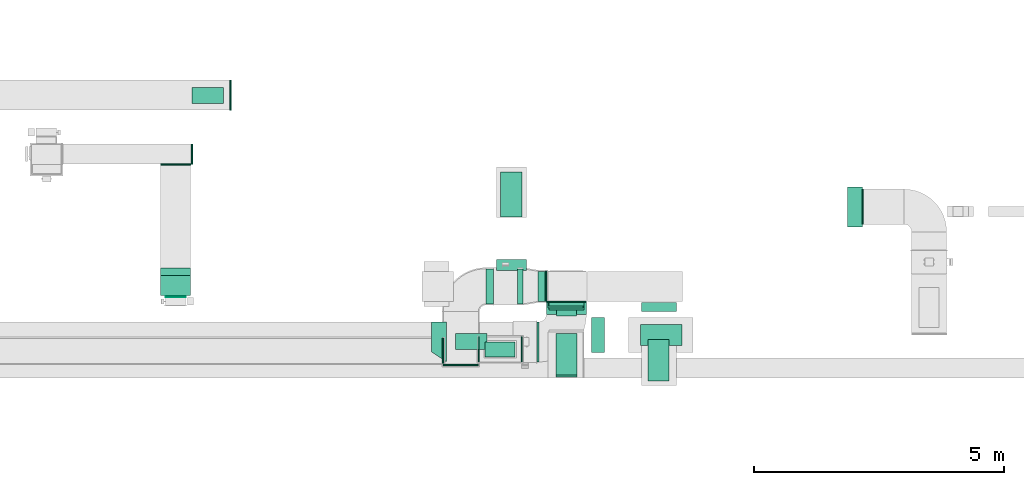
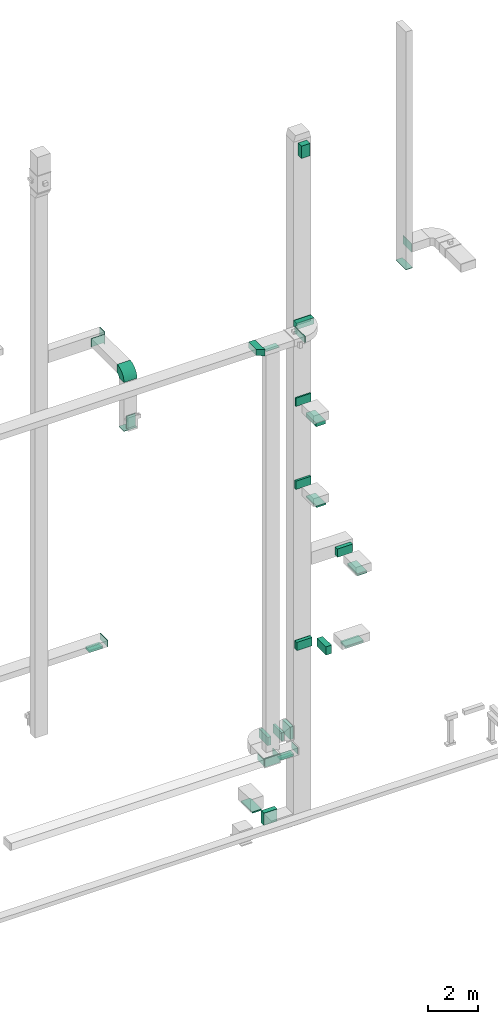
# One storey, part 15 of 25: 22 flow fittings, 20 flow segments, 3 flow terminals.
"""IFC2X3 building model written with IfcOpenShell, lengths in millimetres."""

from ifc_helpers import new_model, entity, si_unit, converted_unit, derived_unit, direction, frame, frame_2d, origin, origin_2d_with_axis, place, context, subcontext, project, spatial, polyline, circle_curve, parameter, trimmed, segment, composite_curve, rectangle, outline, extrude, source, transform, mapped, material, type_object, type_shapes, element, save


model = new_model("IFC2X3")

# Units and contexts
model_context = context("Model", 3, precision=0.01, world=origin(), true_north=direction((6.12303176911189e-17, 1.0)))
body_context = subcontext(model_context, "Body", "Model", "MODEL_VIEW")
ifc_project = project(units=[si_unit("LENGTHUNIT", "METRE", prefix="MILLI"), si_unit("AREAUNIT", "SQUARE_METRE"), si_unit("VOLUMEUNIT", "CUBIC_METRE"), converted_unit("PLANEANGLEUNIT", "DEGREE", entity("IfcRatioMeasure", 0.0174532925199433), si_unit("PLANEANGLEUNIT", "RADIAN"), dimensions=[0, 0, 0, 0, 0, 0, 0]), si_unit("MASSUNIT", "GRAM", prefix="KILO"), derived_unit("MASSDENSITYUNIT", [(si_unit("MASSUNIT", "GRAM", prefix="KILO"), 1), (si_unit("LENGTHUNIT", "METRE"), -3)]), derived_unit("MOMENTOFINERTIAUNIT", [(si_unit("LENGTHUNIT", "METRE"), 4)]), si_unit("TIMEUNIT", "SECOND"), si_unit("FREQUENCYUNIT", "HERTZ"), si_unit("THERMODYNAMICTEMPERATUREUNIT", "DEGREE_CELSIUS"), derived_unit("THERMALTRANSMITTANCEUNIT", [(si_unit("MASSUNIT", "GRAM", prefix="KILO"), 1), (si_unit("THERMODYNAMICTEMPERATUREUNIT", "KELVIN"), -1), (si_unit("TIMEUNIT", "SECOND"), -3)]), derived_unit("VOLUMETRICFLOWRATEUNIT", [(si_unit("LENGTHUNIT", "METRE"), 3), (si_unit("TIMEUNIT", "SECOND"), -1)]), derived_unit("MASSFLOWRATEUNIT", [(si_unit("MASSUNIT", "GRAM", prefix="KILO"), 1), (si_unit("TIMEUNIT", "SECOND"), -1)]), derived_unit("ROTATIONALFREQUENCYUNIT", [(si_unit("TIMEUNIT", "SECOND"), -1)]), si_unit("ELECTRICCURRENTUNIT", "AMPERE"), si_unit("ELECTRICVOLTAGEUNIT", "VOLT"), si_unit("POWERUNIT", "WATT"), si_unit("FORCEUNIT", "NEWTON", prefix="KILO"), si_unit("ILLUMINANCEUNIT", "LUX"), si_unit("LUMINOUSFLUXUNIT", "LUMEN"), si_unit("LUMINOUSINTENSITYUNIT", "CANDELA"), derived_unit("USERDEFINED", [(si_unit("MASSUNIT", "GRAM", prefix="KILO"), -1), (si_unit("LENGTHUNIT", "METRE"), -2), (si_unit("TIMEUNIT", "SECOND"), 3), (si_unit("LUMINOUSFLUXUNIT", "LUMEN"), 1)]), derived_unit("LINEARVELOCITYUNIT", [(si_unit("LENGTHUNIT", "METRE"), 1), (si_unit("TIMEUNIT", "SECOND"), -1)]), si_unit("PRESSUREUNIT", "PASCAL"), derived_unit("USERDEFINED", [(si_unit("LENGTHUNIT", "METRE"), -2), (si_unit("MASSUNIT", "GRAM", prefix="KILO"), 1), (si_unit("TIMEUNIT", "SECOND"), -2)]), derived_unit("LINEARFORCEUNIT", [(si_unit("MASSUNIT", "GRAM", prefix="KILO"), 1), (si_unit("LENGTHUNIT", "METRE"), 1), (si_unit("TIMEUNIT", "SECOND"), -2), (si_unit("LENGTHUNIT", "METRE"), -1)]), derived_unit("PLANARFORCEUNIT", [(si_unit("MASSUNIT", "GRAM", prefix="KILO"), 1), (si_unit("LENGTHUNIT", "METRE"), 1), (si_unit("TIMEUNIT", "SECOND"), -2), (si_unit("LENGTHUNIT", "METRE"), -2)])], contexts=[model_context])

# Site, building, storey
site_placement = place(None, origin())
site = spatial("IfcSite", under=ifc_project, at=site_placement, CompositionType="ELEMENT")
building_placement = place(site_placement, origin())
building = spatial("IfcBuilding", under=site, at=building_placement, CompositionType="ELEMENT")
storey_placement = place(building_placement, origin())
storey = spatial("IfcBuildingStorey", under=building, at=storey_placement, CompositionType="ELEMENT", Elevation=0.0)

# Flow segments
duct_segment_type_1 = type_object("IfcDuctSegmentType", PredefinedType="NOTDEFINED")
flow_segment_1_placement = place(storey_placement, frame((62668.85, 10217.03, 30600.0)))
element("IfcFlowSegment", 1, at=flow_segment_1_placement, inside=storey, type_object=duct_segment_type_1, context=body_context, shape_type="SweptSolid", body=[
    extrude(rectangle(XDim=271.467042236398, YDim=400.000000000004, at=origin_2d_with_axis()), frame((200.0, 135.73, 0.0), z_axis=(0.0, 0.0, 1.0), x_axis=(0.0, 1.0, 0.0)), (0.0, 0.0, 1.0), 600.000000000002),
])
flow_segment_2_placement = place(storey_placement, frame((62659.63, 9000.34, 14399.25)))
element("IfcFlowSegment", 2, at=flow_segment_2_placement, inside=storey, type_object=duct_segment_type_1, context=body_context, shape_type="SweptSolid", body=[
    extrude(rectangle(XDim=425.000000000007, YDim=825.0, at=origin_2d_with_axis()), frame((212.5, 412.5, 0.0)), (0.0, 0.0, 1.0), 80.7499999999946),
])
flow_segment_3_placement = place(storey_placement, frame((64497.81, 8920.34, 10500.0)))
element("IfcFlowSegment", 3, at=flow_segment_3_placement, inside=storey, type_object=duct_segment_type_1, context=body_context, shape_type="SweptSolid", body=[
    extrude(rectangle(XDim=825.000000000001, YDim=424.999999999999, at=origin_2d_with_axis()), frame((212.5, 412.5, 0.0), z_axis=(0.0, 0.0, 1.0), x_axis=(0.0, 1.0, 0.0)), (0.0, 0.0, 1.0), 79.9999999999818),
])
flow_segment_4_placement = place(storey_placement, frame((62661.63, 9040.34, 18299.51)))
element("IfcFlowSegment", 4, at=flow_segment_4_placement, inside=storey, type_object=duct_segment_type_1, context=body_context, shape_type="SweptSolid", body=[
    extrude(rectangle(XDim=425.000000000007, YDim=825.0, at=origin_2d_with_axis()), frame((212.5, 412.5, 0.0), z_axis=(0.0, 0.0, 1.0), x_axis=(-1.0, 0.0, 0.0)), (0.0, 0.0, 1.0), 180.490931807302),
])
flow_segment_5_placement = place(storey_placement, frame((64355.36, 9625.06, 6600.0)))
element("IfcFlowSegment", 5, at=flow_segment_5_placement, inside=storey, type_object=duct_segment_type_1, context=body_context, shape_type="SweptSolid", body=[
    extrude(rectangle(XDim=425.0, YDim=825.000000000003, at=origin_2d_with_axis()), frame((412.5, 212.5, 0.0), z_axis=(0.0, 0.0, 1.0), x_axis=(0.0, -1.0, 0.0)), (0.0, 0.0, 1.0), 79.9999999999991),
])
flow_segment_6_placement = place(storey_placement, frame((62307.09, 10508.51, 2350.0)))
element("IfcFlowSegment", 6, at=flow_segment_6_placement, inside=storey, type_object=duct_segment_type_1, context=body_context, shape_type="SweptSolid", body=[
    extrude(rectangle(XDim=143.50000000008, YDim=600.0, at=origin_2d_with_axis()), frame((71.75, 300.0, 0.0), z_axis=(0.0, 0.0, 1.0), x_axis=(-1.0, 0.0, 0.0)), (0.0, 0.0, 1.0), 600.0),
])
flow_segment_7_placement = place(storey_placement, frame((61244.35, 9400.08, 2400.0)))
element("IfcFlowSegment", 7, at=flow_segment_7_placement, inside=storey, type_object=duct_segment_type_1, context=body_context, shape_type="SweptSolid", body=[
    extrude(rectangle(XDim=600.000000000002, YDim=300.0, at=origin_2d_with_axis()), frame((300.0, 150.0, 0.0)), (0.0, 0.0, 1.0), 79.999999999987),
])
flow_segment_8_placement = place(storey_placement, frame((61557.63, 12193.5, -1980.0)))
element("IfcFlowSegment", 8, at=flow_segment_8_placement, inside=storey, type_object=duct_segment_type_1, context=body_context, shape_type="SweptSolid", body=[
    extrude(rectangle(XDim=900.0, YDim=425.000000000004, at=origin_2d_with_axis()), frame((212.5, 450.0, 0.0), z_axis=(0.0, 0.0, 1.0), x_axis=(4.54891432006358e-06, 1.0, 0.0)), (0.0, 0.0, 1.0), 60.4869889686039),
])
flow_segment_9_placement = place(storey_placement, frame((61470.14, 11128.5, -1899.51)))
element("IfcFlowSegment", 9, at=flow_segment_9_placement, inside=storey, type_object=duct_segment_type_1, context=body_context, shape_type="SweptSolid", body=[
    extrude(rectangle(XDim=221.220937838014, YDim=600.000000000002, at=origin_2d_with_axis()), frame((300.0, 110.61, 0.0), z_axis=(0.0, 0.0, 1.0), x_axis=(0.0, 1.0, 0.0)), (0.0, 0.0, 1.0), 600.0),
])
flow_segment_10_placement = place(storey_placement, frame((55390.61, 14462.37, 6600.0)))
element("IfcFlowSegment", 10, at=flow_segment_10_placement, inside=storey, type_object=duct_segment_type_1, context=body_context, shape_type="SweptSolid", body=[
    extrude(rectangle(XDim=324.999999999998, YDim=624.999999999996, at=origin_2d_with_axis()), frame((312.5, 162.5, 0.0), z_axis=(0.0, 0.0, 1.0), x_axis=(0.0, -1.0, 0.0)), (0.0, 0.0, 1.0), 80.0000000000002),
])
flow_segment_11_placement = place(storey_placement, frame((62507.0, 10379.54, 14500.0)))
element("IfcFlowSegment", 11, at=flow_segment_11_placement, inside=storey, type_object=duct_segment_type_1, context=body_context, shape_type="SweptSolid", body=[
    extrude(rectangle(XDim=104.948641174258, YDim=700.0, at=origin_2d_with_axis()), frame((350.01, 52.52, 0.0), z_axis=(0.0, 0.0, 1.0), x_axis=(-0.000129957297672545, 0.99999999155555, 0.0)), (0.0, 0.0, 1.0), 400.0),
])
flow_segment_12_placement = place(storey_placement, frame((62518.99, 10412.6, 18500.0)))
element("IfcFlowSegment", 12, at=flow_segment_12_placement, inside=storey, type_object=duct_segment_type_1, context=body_context, shape_type="SweptSolid", body=[
    extrude(rectangle(XDim=71.0457855893592, YDim=700.000000000003, at=origin_2d_with_axis()), frame((350.01, 35.58, 0.0), z_axis=(0.0, 0.0, 1.0), x_axis=(-0.000157457136900827, 0.999999987603625, 0.0)), (0.0, 0.0, 1.0), 400.0),
])
flow_segment_13_placement = place(storey_placement, frame((62469.72, 10248.83, 22350.0)))
element("IfcFlowSegment", 13, at=flow_segment_13_placement, inside=storey, type_object=duct_segment_type_1, context=body_context, shape_type="SweptSolid", body=[
    extrude(rectangle(XDim=239.665570609249, YDim=800.000000000004, at=origin_2d_with_axis()), frame((400.0, 119.83, 0.0), z_axis=(0.0, 0.0, 1.0), x_axis=(-3.44018263539569e-06, -1.0, 0.0)), (0.0, 0.0, 1.0), 300.000000000001),
])
flow_segment_14_placement = place(storey_placement, frame((62279.43, 9298.83, 22350.0)))
element("IfcFlowSegment", 14, at=flow_segment_14_placement, inside=storey, type_object=duct_segment_type_1, context=body_context, shape_type="SweptSolid", body=[
    extrude(rectangle(XDim=40.2898557493053, YDim=800.000000000001, at=origin_2d_with_axis()), frame((20.14, 400.0, 0.0), z_axis=(0.0, 0.0, 1.0), x_axis=(-1.0, 0.0, 0.0)), (0.0, 0.0, 1.0), 300.000000000001),
])
flow_segment_15_placement = place(storey_placement, frame((63370.68, 9485.39, 6700.0)))
element("IfcFlowSegment", 15, at=flow_segment_15_placement, inside=storey, type_object=duct_segment_type_1, context=body_context, shape_type="SweptSolid", body=[
    extrude(rectangle(XDim=259.316891872014, YDim=700.000000000001, at=origin_2d_with_axis()), frame((129.66, 350.0, 0.0), z_axis=(0.0, 0.0, 1.0), x_axis=(-1.0, 0.0, 0.0)), (0.0, 0.0, 1.0), 400.0),
])
flow_segment_16_placement = place(storey_placement, frame((62520.68, 10335.39, 6700.0)))
element("IfcFlowSegment", 16, at=flow_segment_16_placement, inside=storey, type_object=duct_segment_type_1, context=body_context, shape_type="SweptSolid", body=[
    extrude(rectangle(XDim=153.114137751644, YDim=699.999999999997, at=origin_2d_with_axis()), frame((350.0, 76.56, 0.0), z_axis=(0.0, 0.0, 1.0), x_axis=(0.0, 1.0, 0.0)), (0.0, 0.0, 1.0), 400.0),
])
flow_segment_17_placement = place(storey_placement, frame((61897.5, 10458.55, 2450.0)))
element("IfcFlowSegment", 17, at=flow_segment_17_placement, inside=storey, type_object=duct_segment_type_1, context=body_context, shape_type="SweptSolid", body=[
    extrude(rectangle(XDim=109.586325142914, YDim=699.999999999999, at=origin_2d_with_axis()), frame((54.79, 350.0, 0.0)), (0.0, 0.0, 1.0), 400.0),
])
flow_segment_18_placement = place(storey_placement, frame((61262.47, 10458.5, 2450.0)))
element("IfcFlowSegment", 18, at=flow_segment_18_placement, inside=storey, type_object=duct_segment_type_1, context=body_context, shape_type="SweptSolid", body=[
    extrude(rectangle(XDim=154.999999573748, YDim=700.000000000001, at=origin_2d_with_axis()), frame((77.53, 350.01, 0.0), z_axis=(0.0, 0.0, 1.0), x_axis=(0.999999997250103, 7.41605989985116e-05, 0.0)), (0.0, 0.0, 1.0), 400.0),
])
flow_segment_19_placement = place(storey_placement, frame((64372.31, 10305.66, 10600.0)))
element("IfcFlowSegment", 19, at=flow_segment_19_placement, inside=storey, type_object=duct_segment_type_1, context=body_context, shape_type="SweptSolid", body=[
    extrude(rectangle(XDim=182.843681330892, YDim=699.999999999997, at=origin_2d_with_axis()), frame((350.0, 91.42, 0.0), z_axis=(0.0, 0.0, 1.0), x_axis=(0.0, 1.0, 0.0)), (0.0, 0.0, 1.0), 400.0),
])
duct_segment_type_2 = type_object("IfcDuctSegmentType", PredefinedType="NOTDEFINED")
flow_segment_20_placement = place(storey_placement, frame((54859.3, 10592.51, 20000.0)))
element("IfcFlowSegment", 20, at=flow_segment_20_placement, inside=storey, type_object=duct_segment_type_2, context=body_context, shape_type="SweptSolid", body=[
    extrude(rectangle(XDim=14.9999999999814, YDim=400.000000000004, at=origin_2d_with_axis()), frame((200.0, 7.5, 0.0), z_axis=(0.0, 0.0, 1.0), x_axis=(0.0, -1.0, 0.0)), (0.0, 0.0, 1.0), 600.000000000002),
])

# Flow fittings
ifc_material_1 = material()
duct_fitting_type_1 = type_object("IfcDuctFittingType", PredefinedType="NOTDEFINED", material=ifc_material_1)
shared_shape_1 = source(origin(), body_context, "Body", "SweptSolid", [
    extrude(rectangle(XDim=24.9999999999999, YDim=700.0, at=origin_2d_with_axis()), frame((12.5, 0.0, -200.0)), (0.0, 0.0, 1.0), 400.0),
])
type_shapes(duct_fitting_type_1, [shared_shape_1])
flow_fitting_1_placement = place(storey_placement, frame((60762.5, 9250.09, 2650.0), z_axis=(0.0, 0.0, 1.0), x_axis=(0.0, -1.0, 0.0)))
element("IfcFlowFitting", 21, at=flow_fitting_1_placement, inside=storey, type_object=duct_fitting_type_1, material=ifc_material_1, context=body_context, shape_type="MappedRepresentation", body=[
    mapped(shared_shape_1, transform((0.0, 0.0, 0.0), scale=1.0)),
])
duct_fitting_type_2 = type_object("IfcDuctFittingType", PredefinedType="NOTDEFINED", material=ifc_material_1)
shared_shape_2 = source(origin(), body_context, "Body", "SweptSolid", [
    extrude(rectangle(XDim=26.0960000000006, YDim=400.0, at=origin_2d_with_axis()), frame((6.95, 0.0, -350.0)), (0.0, 0.0, 1.0), 700.0),
])
type_shapes(duct_fitting_type_2, [shared_shape_2])
for number, where, z_axis, x_axis in (
    (22, (68787.5, 12399.6, 23000.0), (0.0, -1.0, 0.0), (1.0, 0.0, 0.0)),
    (23, (62870.68, 10508.5, 6900.0), (-1.0, 0.0, 0.0), (0.0, -1.0, 0.0)),
):
    element("IfcFlowFitting", number, at=place(storey_placement, frame(where, z_axis=z_axis, x_axis=x_axis)), inside=storey, type_object=duct_fitting_type_2, material=ifc_material_1, context=body_context, shape_type="MappedRepresentation", body=[
        mapped(shared_shape_2, transform((0.0, 0.0, 0.0), scale=1.0)),
    ])
duct_fitting_type_3 = type_object("IfcDuctFittingType", PredefinedType="NOTDEFINED", material=ifc_material_1)
shared_shape_3 = source(origin(), body_context, "Body", "SweptSolid", [
    extrude(rectangle(XDim=26.0960000000009, YDim=600.0, at=origin_2d_with_axis()), frame((6.95, 0.0, -200.0)), (0.0, 0.0, 1.0), 400.0),
])
type_shapes(duct_fitting_type_3, [shared_shape_3])
for number, where, z_axis, x_axis in (
    (24, (55060.3, 13249.51, 22600.0), (0.0, 0.0, -1.0), (0.0, -1.0, 0.0)),
    (25, (55059.3, 10627.51, 20300.0), (-1.0, 0.0, 0.0), (0.0, -1.0, 0.0)),
):
    element("IfcFlowFitting", number, at=place(storey_placement, frame(where, z_axis=z_axis, x_axis=x_axis)), inside=storey, type_object=duct_fitting_type_3, material=ifc_material_1, context=body_context, shape_type="MappedRepresentation", body=[
        mapped(shared_shape_3, transform((0.0, 0.0, 0.0), scale=1.0)),
    ])
duct_fitting_type_4 = type_object("IfcDuctFittingType", PredefinedType="NOTDEFINED", material=ifc_material_1)
shared_shape_4 = source(origin(), body_context, "Body", "SweptSolid", [
    extrude(rectangle(XDim=24.9999999999999, YDim=400.0, at=origin_2d_with_axis()), frame((12.5, 0.0, -300.0)), (0.0, 0.0, 1.0), 600.0),
])
type_shapes(duct_fitting_type_4, [shared_shape_4])
flow_fitting_2_placement = place(storey_placement, frame((55376.21, 13449.51, 22600.0)))
element("IfcFlowFitting", 26, at=flow_fitting_2_placement, inside=storey, type_object=duct_fitting_type_4, material=ifc_material_1, context=body_context, shape_type="MappedRepresentation", body=[
    mapped(shared_shape_4, transform((0.0, 0.0, 0.0), scale=1.0)),
])
duct_fitting_type_5 = type_object("IfcDuctFittingType", PredefinedType="NOTDEFINED", material=ifc_material_1)
shared_shape_5 = source(origin(), body_context, "Body", "SweptSolid", [
    extrude(rectangle(XDim=26.0960000000291, YDim=600.0, at=origin_2d_with_axis()), frame((6.95, 0.0, -150.0)), (0.0, 0.0, 1.0), 300.0),
])
type_shapes(duct_fitting_type_5, [shared_shape_5])
flow_fitting_3_placement = place(storey_placement, frame((61544.35, 9550.08, 2500.0), z_axis=(4.54891432388847e-06, 1.0, 0.0), x_axis=(0.0, 0.0, -1.0)))
element("IfcFlowFitting", 27, at=flow_fitting_3_placement, inside=storey, type_object=duct_fitting_type_5, material=ifc_material_1, context=body_context, shape_type="MappedRepresentation", body=[
    mapped(shared_shape_5, transform((0.0, 0.0, 0.0), scale=1.0)),
])
duct_fitting_type_6 = type_object("IfcDuctFittingType", PredefinedType="NOTDEFINED", material=ifc_material_1)
shared_shape_6 = source(origin(), body_context, "Body", "SweptSolid", [
    extrude(rectangle(XDim=24.9999999999999, YDim=600.0, at=origin_2d_with_axis()), frame((12.5, 0.0, -150.0)), (0.0, 0.0, 1.0), 300.0),
])
type_shapes(duct_fitting_type_6, [shared_shape_6])
flow_fitting_4_placement = place(storey_placement, frame((56145.9, 14630.07, 6850.0)))
element("IfcFlowFitting", 28, at=flow_fitting_4_placement, inside=storey, type_object=duct_fitting_type_6, material=ifc_material_1, context=body_context, shape_type="MappedRepresentation", body=[
    mapped(shared_shape_6, transform((0.0, 0.0, 0.0), scale=1.0)),
])

# Flow terminal
ifc_material_2 = material()
air_terminal_type_1 = type_object("IfcAirTerminalType", PredefinedType="NOTDEFINED", material=ifc_material_2)
shared_shape_7 = source(origin(), body_context, "Body", "SweptSolid", [
    extrude(rectangle(XDim=4.0, YDim=599.999999999999, at=origin_2d_with_axis()), frame((0.0, -2.0, -150.0), z_axis=(0.0, 0.0, 1.0), x_axis=(0.0, 1.0, 0.0)), (0.0, 0.0, 1.0), 300.000000000005),
])
type_shapes(air_terminal_type_1, [shared_shape_7])
flow_terminal_placement = place(storey_placement, frame((61544.35, 9550.08, 2400.0), z_axis=(4.54891432388847e-06, 1.0, 0.0), x_axis=(-1.0, 4.54891432388847e-06, 0.0)))
element("IfcFlowTerminal", 29, at=flow_terminal_placement, inside=storey, type_object=air_terminal_type_1, material=ifc_material_2, context=body_context, shape_type="MappedRepresentation", body=[
    mapped(shared_shape_7, transform((0.0, 0.0, 0.0), scale=1.0)),
])

# Flow fittings
duct_fitting_type_7 = type_object("IfcDuctFittingType", PredefinedType="NOTDEFINED", material=ifc_material_1)
shared_shape_8 = source(origin(), body_context, "Body", "SweptSolid", [
    extrude(rectangle(XDim=24.9999999999999, YDim=300.0, at=origin_2d_with_axis()), frame((12.5, 0.0, -400.0)), (0.0, 0.0, 1.0), 800.0),
])
type_shapes(duct_fitting_type_7, [shared_shape_8])
flow_fitting_5_placement = place(storey_placement, frame((68637.5, 12392.6, 22100.0), z_axis=(0.0, -1.0, 0.0), x_axis=(0.0, 0.0, -1.0)))
element("IfcFlowFitting", 30, at=flow_fitting_5_placement, inside=storey, type_object=duct_fitting_type_7, material=ifc_material_1, context=body_context, shape_type="MappedRepresentation", body=[
    mapped(shared_shape_8, transform((0.0, 0.0, 0.0), scale=1.0)),
])
duct_fitting_type_8 = type_object("IfcDuctFittingType", PredefinedType="NOTDEFINED", material=ifc_material_1)
shared_shape_9 = source(origin(), body_context, "Body", "SweptSolid", [
    extrude(rectangle(XDim=24.9999999999999, YDim=600.0, at=origin_2d_with_axis()), frame((12.5, 0.0, -200.0)), (0.0, 0.0, 1.0), 400.0),
])
type_shapes(duct_fitting_type_8, [shared_shape_9])
flow_fitting_6_placement = place(storey_placement, frame((55060.3, 10827.51, 19900.0), z_axis=(0.0, 1.0, 0.0), x_axis=(0.0, 0.0, -1.0)))
element("IfcFlowFitting", 31, at=flow_fitting_6_placement, inside=storey, type_object=duct_fitting_type_8, material=ifc_material_1, context=body_context, shape_type="MappedRepresentation", body=[
    mapped(shared_shape_9, transform((0.0, 0.0, 0.0), scale=1.0)),
])
duct_fitting_type_9 = type_object("IfcDuctFittingType", PredefinedType="NOTDEFINED", material=ifc_material_1)
shared_shape_10 = source(origin(), body_context, "Body", "SweptSolid", [
    extrude(rectangle(XDim=600.0, YDim=26.0960000000043, at=origin_2d_with_axis()), frame((6.95, 0.0, -300.0), z_axis=(0.0, 0.0, 1.0), x_axis=(0.0, -1.0, 0.0)), (0.0, 0.0, 1.0), 600.0),
])
type_shapes(duct_fitting_type_9, [shared_shape_10])
flow_fitting_7_placement = place(storey_placement, frame((62470.59, 10808.51, 2650.0), z_axis=(0.0, 1.0, 0.0), x_axis=(-1.0, 0.0, 0.0)))
element("IfcFlowFitting", 32, at=flow_fitting_7_placement, inside=storey, type_object=duct_fitting_type_9, material=ifc_material_1, context=body_context, shape_type="MappedRepresentation", body=[
    mapped(shared_shape_10, transform((0.0, 0.0, 0.0), scale=1.0)),
])
duct_fitting_type_10 = type_object("IfcDuctFittingType", PredefinedType="NOTDEFINED", material=ifc_material_1)
shared_shape_11 = source(origin(), body_context, "Body", "SweptSolid", [
    extrude(rectangle(XDim=26.0960000000156, YDim=300.0, at=origin_2d_with_axis()), frame((6.95, 0.0, -400.0)), (0.0, 0.0, 1.0), 800.0),
])
type_shapes(duct_fitting_type_10, [shared_shape_11])
flow_fitting_8_placement = place(storey_placement, frame((62868.7, 10508.5, 22500.0), z_axis=(-1.0, 0.0, 0.0), x_axis=(0.0, -1.0, 0.0)))
element("IfcFlowFitting", 33, at=flow_fitting_8_placement, inside=storey, type_object=duct_fitting_type_10, material=ifc_material_1, context=body_context, shape_type="MappedRepresentation", body=[
    mapped(shared_shape_11, transform((0.0, 0.0, 0.0), scale=1.0)),
])
duct_fitting_type_11 = type_object("IfcDuctFittingType", PredefinedType="NOTDEFINED", material=ifc_material_1)
shared_shape_12 = source(origin(), body_context, "Body", "SweptSolid", [
    extrude(rectangle(XDim=425.0, YDim=26.0960000000087, at=origin_2d_with_axis()), frame((6.95, 0.0, -412.5), z_axis=(0.0, 0.0, 1.0), x_axis=(0.0, -1.0, 0.0)), (0.0, 0.0, 1.0), 825.0),
])
type_shapes(duct_fitting_type_11, [shared_shape_12])
for number, where, z_axis, x_axis in (
    (34, (64710.31, 9332.84, 10600.0), (0.0, 1.0, 0.0), (0.0, 0.0, -1.0)),
    (35, (64767.86, 9837.56, 6700.0), (1.0, 0.0, 0.0), (0.0, 0.0, -1.0)),
):
    element("IfcFlowFitting", number, at=place(storey_placement, frame(where, z_axis=z_axis, x_axis=x_axis)), inside=storey, type_object=duct_fitting_type_11, material=ifc_material_1, context=body_context, shape_type="MappedRepresentation", body=[
        mapped(shared_shape_12, transform((0.0, 0.0, 0.0), scale=1.0)),
    ])
duct_fitting_type_12 = type_object("IfcDuctFittingType", PredefinedType="NOTDEFINED", material=ifc_material_1)
shared_shape_13 = source(origin(), body_context, "Body", "SweptSolid", [
    extrude(rectangle(XDim=24.9999999999999, YDim=500.0, at=origin_2d_with_axis()), frame((12.5, 0.0, -150.0)), (0.0, 0.0, 1.0), 300.0),
])
type_shapes(duct_fitting_type_12, [shared_shape_13])
flow_fitting_9_placement = place(storey_placement, frame((61964.28, 9550.08, 2650.0)))
element("IfcFlowFitting", 36, at=flow_fitting_9_placement, inside=storey, type_object=duct_fitting_type_12, material=ifc_material_1, context=body_context, shape_type="MappedRepresentation", body=[
    mapped(shared_shape_13, transform((0.0, 0.0, 0.0), scale=1.0)),
])

# Flow terminals
air_terminal_type_2 = type_object("IfcAirTerminalType", PredefinedType="NOTDEFINED", material=ifc_material_2)
shared_shape_14 = source(origin(), body_context, "Body", "SweptSolid", [
    extrude(rectangle(XDim=4.0, YDim=624.999999999999, at=origin_2d_with_axis()), frame((0.0, -2.0, -162.5), z_axis=(0.0, 0.0, 1.0), x_axis=(0.0, 1.0, 0.0)), (0.0, 0.0, 1.0), 325.000000000005),
])
type_shapes(air_terminal_type_2, [shared_shape_14])
for number, where, z_axis, x_axis in (
    (37, (60967.35, 9707.95, 2395.0), (0.0, -1.0, 0.0), (1.0, 0.0, 0.0)),
    (38, (55703.11, 14624.87, 6600.0), (-1.61069216523556e-08, 1.0, 0.0), (-1.0, -1.61069216523556e-08, 0.0)),
):
    element("IfcFlowTerminal", number, at=place(storey_placement, frame(where, z_axis=z_axis, x_axis=x_axis)), inside=storey, type_object=air_terminal_type_2, material=ifc_material_2, context=body_context, shape_type="MappedRepresentation", body=[
        mapped(shared_shape_14, transform((0.0, 0.0, 0.0), scale=1.0)),
    ])

# Flow fittings
duct_fitting_type_13 = type_object("IfcDuctFittingType", PredefinedType="NOTDEFINED", material=ifc_material_1)
shared_shape_15 = source(origin(), body_context, "Body", "SweptSolid", [
    extrude(rectangle(XDim=26.096000000001, YDim=625.0, at=origin_2d_with_axis()), frame((6.95, 0.0, -162.5)), (0.0, 0.0, 1.0), 325.0),
])
type_shapes(duct_fitting_type_13, [shared_shape_15])
flow_fitting_10_placement = place(storey_placement, frame((60967.35, 9707.95, 22350.0), z_axis=(0.0, -1.0, 0.0), x_axis=(0.0, 0.0, -1.0)))
element("IfcFlowFitting", 39, at=flow_fitting_10_placement, inside=storey, type_object=duct_fitting_type_13, material=ifc_material_1, context=body_context, shape_type="MappedRepresentation", body=[
    mapped(shared_shape_15, transform((0.0, 0.0, 0.0), scale=1.0)),
])
duct_fitting_type_14 = type_object("IfcDuctFittingType", PredefinedType="NOTDEFINED", material=ifc_material_1)
shared_shape_16 = source(origin(), body_context, "Body", "SweptSolid", [
    extrude(rectangle(XDim=625.0, YDim=26.0960000000195, at=origin_2d_with_axis()), frame((6.95, 0.0, -162.5), z_axis=(0.0, 0.0, 1.0), x_axis=(0.0, -1.0, 0.0)), (0.0, 0.0, 1.0), 325.0),
])
type_shapes(duct_fitting_type_14, [shared_shape_16])
flow_fitting_11_placement = place(storey_placement, frame((55703.11, 14624.87, 6700.0), z_axis=(0.0, -1.0, 0.0), x_axis=(0.0, 0.0, -1.0)))
element("IfcFlowFitting", 40, at=flow_fitting_11_placement, inside=storey, type_object=duct_fitting_type_14, material=ifc_material_1, context=body_context, shape_type="MappedRepresentation", body=[
    mapped(shared_shape_16, transform((0.0, 0.0, 0.0), scale=1.0)),
])
duct_fitting_type_15 = type_object("IfcDuctFittingType", PredefinedType="NOTDEFINED", material=ifc_material_1)
shared_shape_17 = source(origin(), body_context, "Body", "SweptSolid", [
    extrude(rectangle(XDim=26.1213371379491, YDim=500.0, at=origin_2d_with_axis()), frame((6.95, 0.0, -150.0)), (0.0, 0.0, 1.0), 300.0),
])
type_shapes(duct_fitting_type_15, [shared_shape_17])
flow_fitting_12_placement = place(storey_placement, frame((60412.5, 9517.34, 2650.0), z_axis=(0.0, 0.0, -1.0), x_axis=(-1.0, 0.0, 0.0)))
element("IfcFlowFitting", 41, at=flow_fitting_12_placement, inside=storey, type_object=duct_fitting_type_15, material=ifc_material_1, context=body_context, shape_type="MappedRepresentation", body=[
    mapped(shared_shape_17, transform((0.0, 0.0, 0.0), scale=1.0)),
])
duct_fitting_type_16 = type_object("IfcDuctFittingType", PredefinedType="NOTDEFINED", material=ifc_material_1)
shared_shape_18 = source(origin(), body_context, "Body", "SweptSolid", [
    extrude(rectangle(XDim=500.0, YDim=26.096, at=origin_2d_with_axis()), frame((6.95, 0.0, -150.0), z_axis=(0.0, 0.0, 1.0), x_axis=(0.0, -1.0, 0.0)), (0.0, 0.0, 1.0), 300.0),
])
type_shapes(duct_fitting_type_16, [shared_shape_18])
flow_fitting_13_placement = place(storey_placement, frame((61112.5, 9550.08, 2650.0), z_axis=(0.0, 0.0, -1.0), x_axis=(1.0, 0.0, 0.0)))
element("IfcFlowFitting", 42, at=flow_fitting_13_placement, inside=storey, type_object=duct_fitting_type_16, material=ifc_material_1, context=body_context, shape_type="MappedRepresentation", body=[
    mapped(shared_shape_18, transform((0.0, 0.0, 0.0), scale=1.0)),
])
duct_fitting_type_17 = type_object("IfcDuctFittingType", PredefinedType="NOTDEFINED", material=ifc_material_1)
shared_shape_19 = source(origin(), body_context, "Body", "SweptSolid", [
    extrude(outline(polyline([(-150.0, -350.0), (150.0, -350.0), (150.0, 250.0), (-150.0, 450.0), (-150.0, -350.0)])), frame((150.0, -50.0, -150.0)), (0.0, 0.0, 1.0), 300.0),
])
type_shapes(duct_fitting_type_17, [shared_shape_19])
flow_fitting_14_placement = place(storey_placement, frame((60475.34, 9699.96, 22500.0), z_axis=(0.0, 0.0, 1.0), x_axis=(-0.999999805808052, 0.000623204507744245, 0.0)))
element("IfcFlowFitting", 43, at=flow_fitting_14_placement, inside=storey, type_object=duct_fitting_type_17, material=ifc_material_1, context=body_context, shape_type="MappedRepresentation", body=[
    mapped(shared_shape_19, transform((0.0, 0.0, 0.0), scale=1.0)),
])
duct_fitting_type_18 = type_object("IfcDuctFittingType", PredefinedType="NOTDEFINED", material=ifc_material_1)
shared_shape_20 = source(origin(), body_context, "Body", "SweptSolid", [
    extrude(rectangle(XDim=26.0970320547895, YDim=300.0, at=origin_2d_with_axis()), frame((6.95, 0.0, -400.0)), (0.0, 0.0, 1.0), 800.0),
])
type_shapes(duct_fitting_type_18, [shared_shape_20])
flow_fitting_15_placement = place(storey_placement, frame((62869.72, 10508.5, 22500.0), z_axis=(-1.0, 3.44018264489101e-06, 0.0), x_axis=(-3.44018264489101e-06, -1.0, 0.0)))
element("IfcFlowFitting", 44, at=flow_fitting_15_placement, inside=storey, type_object=duct_fitting_type_18, material=ifc_material_1, context=body_context, shape_type="MappedRepresentation", body=[
    mapped(shared_shape_20, transform((0.0, 0.0, 0.0), scale=1.0)),
])
duct_fitting_type_19 = type_object("IfcDuctFittingType", PredefinedType="NOTDEFINED", material=ifc_material_1)
shared_shape_21 = source(origin(), body_context, "Body", "SweptSolid", [
    extrude(outline(composite_curve([segment(polyline([(-375.0, -175.0), (25.0, -175.0)]), True, "CONTINUOUS"), segment(trimmed(circle_curve(frame_2d((175.0, -175.0), x_axis=(0.0, 1.0)), 150.0), [parameter(0.0)], [parameter(90.0000000000001)], True, "PARAMETER"), False, "CONTINUOUS"), segment(polyline([(175.0, -25.0), (175.0, 375.0)]), True, "CONTINUOUS"), segment(trimmed(circle_curve(frame_2d((175.0, -175.0), x_axis=(0.0, 1.0)), 550.0), [parameter(0.0)], [parameter(90.0)], True, "PARAMETER"), True, "CONTINUOUS")], self_intersect=False)), frame((-175.0, 175.0, -300.0), z_axis=(0.0, 0.0, 1.0), x_axis=(-1.0, 0.0, 0.0)), (0.0, 0.0, 1.0), 600.0),
])
type_shapes(duct_fitting_type_19, [shared_shape_21])
flow_fitting_16_placement = place(storey_placement, frame((55060.3, 10827.51, 22600.0), z_axis=(1.0, 0.0, 0.0), x_axis=(0.0, -1.0, 0.0)))
element("IfcFlowFitting", 45, at=flow_fitting_16_placement, inside=storey, type_object=duct_fitting_type_19, material=ifc_material_1, context=body_context, shape_type="MappedRepresentation", body=[
    mapped(shared_shape_21, transform((0.0, 0.0, 0.0), scale=1.0)),
])

save(model, "model.ifc")
